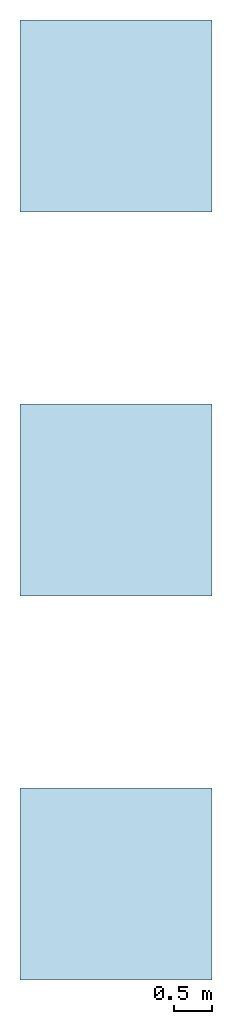
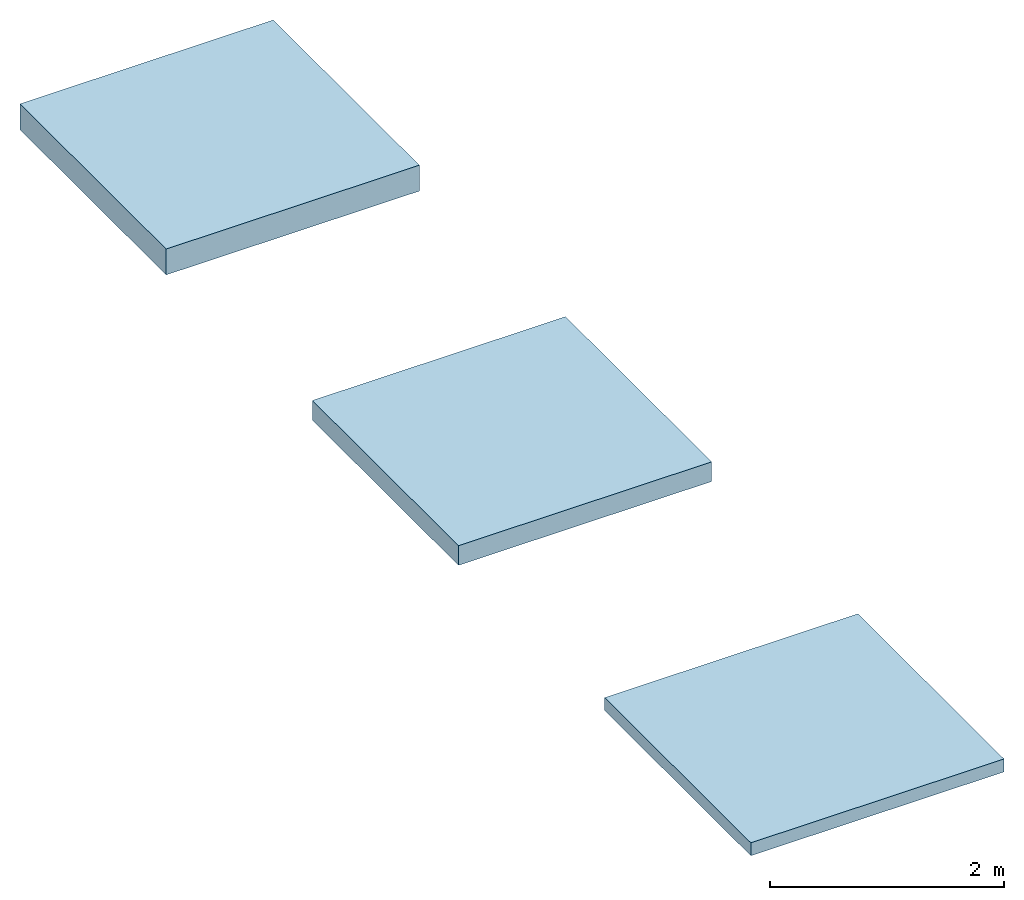
# Not in any storey: 3 slabs.
"""IFC2X3 building model written with IfcOpenShell, lengths in millimetres."""

from ifc_helpers import new_model, si_unit, frame, frame_2d, origin, origin_with_axes, origin_2d, place, context, project, spatial, rectangle, extrude, material, layer, layer_set, layer_usage, type_object, element, save


model = new_model("IFC2X3")

# Units and contexts
model_context = context("Model", 3, precision=1e-05, world=origin())
plan_context = context("Plan", 2, precision=1e-05, world=origin_2d())
ifc_project = project(units=[si_unit("LENGTHUNIT", "METRE", prefix="MILLI"), si_unit("AREAUNIT", "SQUARE_METRE"), si_unit("VOLUMEUNIT", "CUBIC_METRE"), si_unit("SOLIDANGLEUNIT", "STERADIAN"), si_unit("PLANEANGLEUNIT", "RADIAN"), si_unit("MASSUNIT", "GRAM"), si_unit("TIMEUNIT", "SECOND"), si_unit("THERMODYNAMICTEMPERATUREUNIT", "DEGREE_CELSIUS"), si_unit("LUMINOUSINTENSITYUNIT", "LUMEN")], contexts=[model_context, plan_context])

# Site, building
site_placement = place(None, frame((0.0, 0.0, 0.0), z_axis=(0.0, 1.0, 0.0), x_axis=(0.0, 0.0, 1.0)))
site = spatial("IfcSite", under=ifc_project, at=site_placement, CompositionType="ELEMENT")
building_placement = place(site_placement, frame((0.0, 0.0, 0.0), z_axis=(0.0, 1.0, 0.0), x_axis=(0.0, 0.0, 1.0)))
building = spatial("IfcBuilding", under=site, at=building_placement, Name="Default building", CompositionType="ELEMENT")

# Slabs
ifc_material_1 = material()
ifc_layer_1 = layer(ifc_material_1, 135.0, ventilated=False)
ifc_layer_set_1 = layer_set([ifc_layer_1])
ifc_layer_usage_1 = layer_usage(ifc_layer_set_1, "AXIS3", "NEGATIVE", 0.0)
slab_type_1 = type_object("IfcSlabType", PredefinedType="FLOOR", material=ifc_layer_set_1)
slab_1_placement = place(None, origin())
element("IfcSlab", 1, at=slab_1_placement, inside=building, type_object=slab_type_1, material=ifc_layer_usage_1, PredefinedType="FLOOR", context=model_context, shape_type="SweptSolid", body=[
    extrude(rectangle(XDim=2500.0, YDim=2500.0, at=frame_2d((1250.0, 1250.0))), origin_with_axes(), (0.0, 0.0, 1.0), 135.0),
])
ifc_material_2 = material()
ifc_layer_2 = layer(ifc_material_2, 205.0, ventilated=False)
ifc_layer_set_2 = layer_set([ifc_layer_2])
ifc_layer_usage_2 = layer_usage(ifc_layer_set_2, "AXIS3", "NEGATIVE", 0.0)
slab_type_2 = type_object("IfcSlabType", PredefinedType="FLOOR", material=ifc_layer_set_2)
slab_2_placement = place(None, frame((0.0, 5000.0, 0.0)))
element("IfcSlab", 2, at=slab_2_placement, inside=building, type_object=slab_type_2, material=ifc_layer_usage_2, PredefinedType="FLOOR", context=model_context, shape_type="SweptSolid", body=[
    extrude(rectangle(XDim=2500.0, YDim=2500.0, at=frame_2d((1250.0, 1250.0))), origin_with_axes(), (0.0, 0.0, 1.0), 205.0),
])
ifc_material_3 = material()
ifc_layer_3 = layer(ifc_material_3, 270.0, ventilated=False)
ifc_layer_set_3 = layer_set([ifc_layer_3])
ifc_layer_usage_3 = layer_usage(ifc_layer_set_3, "AXIS3", "NEGATIVE", 0.0)
slab_type_3 = type_object("IfcSlabType", PredefinedType="FLOOR", material=ifc_layer_set_3)
slab_3_placement = place(None, frame((0.0, 10000.0, 0.0)))
element("IfcSlab", 3, at=slab_3_placement, inside=building, type_object=slab_type_3, material=ifc_layer_usage_3, PredefinedType="FLOOR", context=model_context, shape_type="SweptSolid", body=[
    extrude(rectangle(XDim=2500.0, YDim=2500.0, at=frame_2d((1250.0, 1250.0))), origin_with_axes(), (0.0, 0.0, 1.0), 270.0),
])

save(model, "model.ifc")
